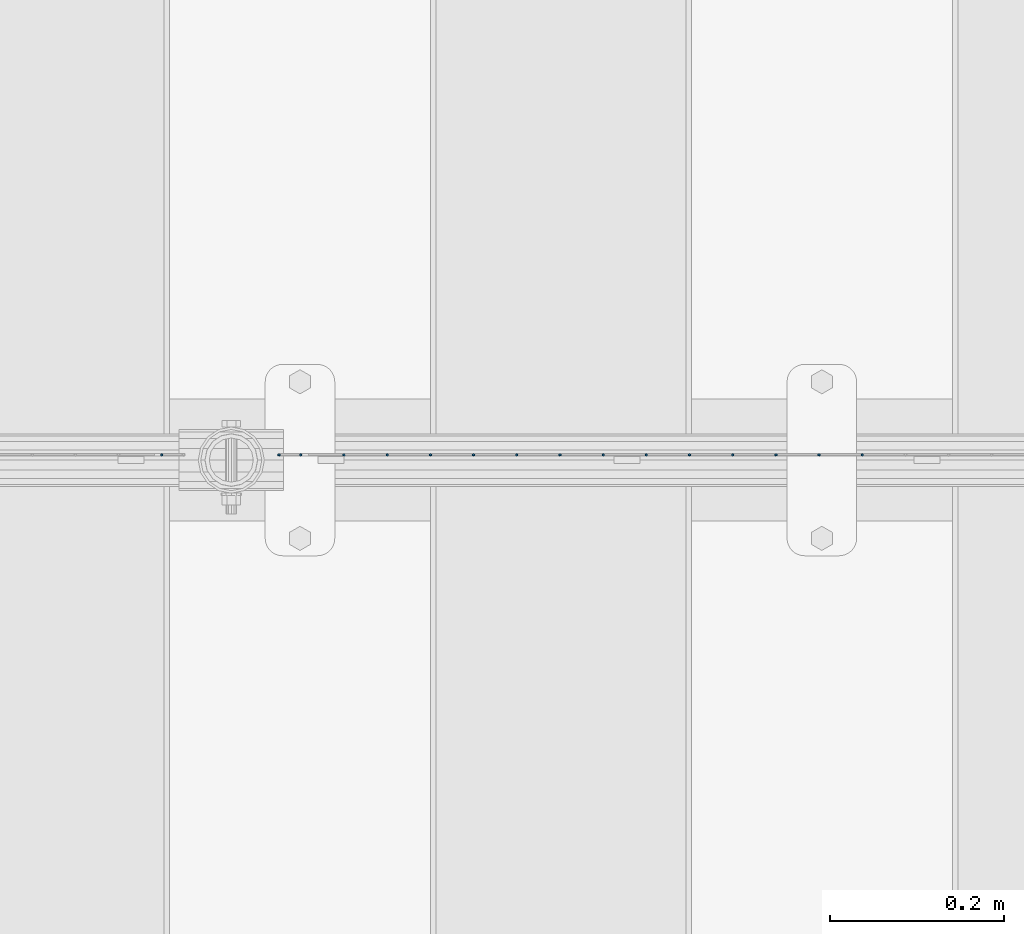
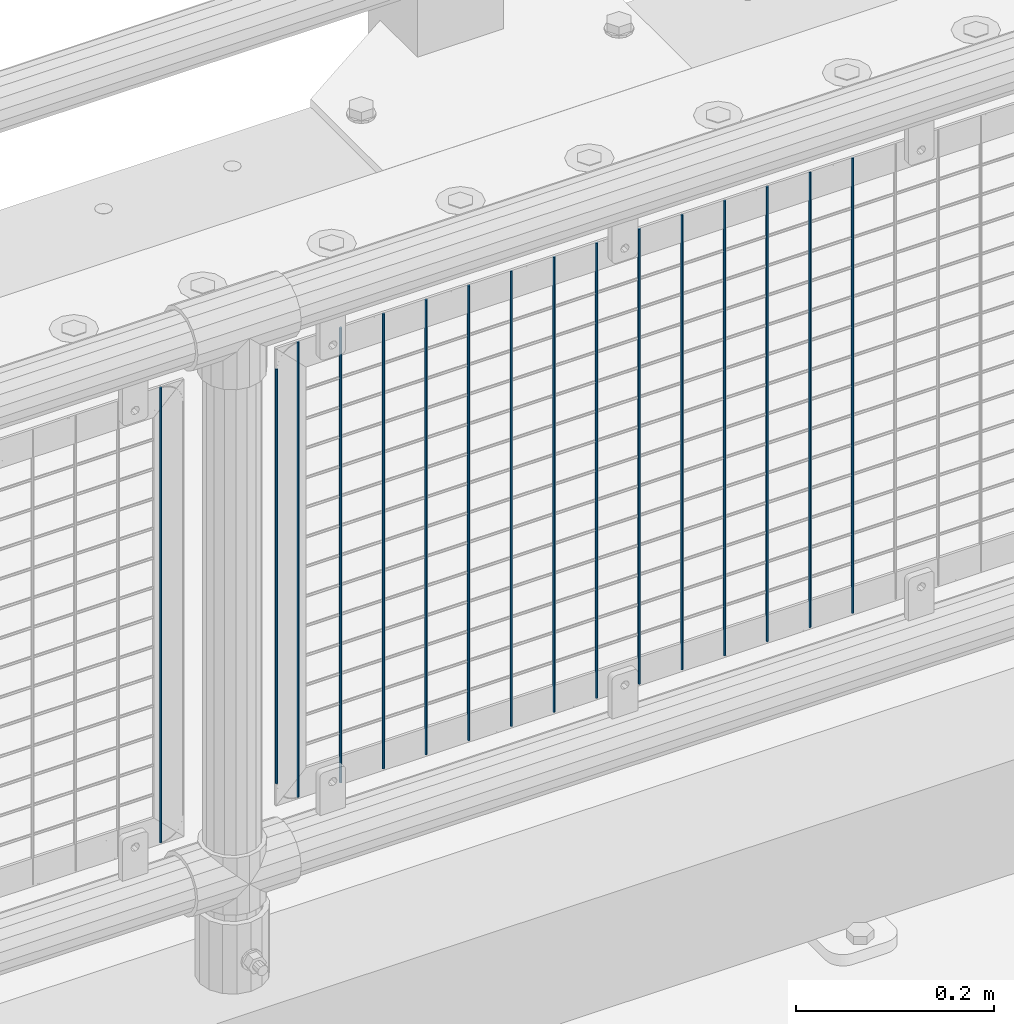
# One storey, part 75 of 208: 16 columns.
"""IFC2X3 building model written with IfcOpenShell, lengths in millimetres."""

from ifc_helpers import new_model, si_unit, frame, origin_with_axes, place, context, subcontext, project, spatial, faceted_brep, material, type_object, element, save


model = new_model("IFC2X3")

# Units and contexts
model_context = context("Model", 3, precision=1e-05, world=origin_with_axes())
body_context = subcontext(model_context, "Body", "Model", "MODEL_VIEW")
ifc_project = project(units=[si_unit("LENGTHUNIT", "METRE", prefix="MILLI"), si_unit("AREAUNIT", "SQUARE_METRE"), si_unit("VOLUMEUNIT", "CUBIC_METRE"), si_unit("MASSUNIT", "GRAM", prefix="KILO"), si_unit("TIMEUNIT", "SECOND"), si_unit("PLANEANGLEUNIT", "RADIAN"), si_unit("SOLIDANGLEUNIT", "STERADIAN"), si_unit("THERMODYNAMICTEMPERATUREUNIT", "DEGREE_CELSIUS"), si_unit("LUMINOUSINTENSITYUNIT", "LUMEN")], contexts=[model_context])

# Site, building, storey
site_placement = place(None, origin_with_axes())
site = spatial("IfcSite", under=ifc_project, at=site_placement, CompositionType="ELEMENT")
building_placement = place(site_placement, origin_with_axes())
building = spatial("IfcBuilding", under=site, at=building_placement, Name="Standard", CompositionType="ELEMENT")
storey_placement = place(building_placement, origin_with_axes())
storey = spatial("IfcBuildingStorey", under=building, at=storey_placement, Name="Undefined", CompositionType="ELEMENT", Elevation=0.0)

# Columns
ifc_material = material(Name="Misc_Undefined")
column_type = type_object("IfcColumnType", Name="D3", PredefinedType="NOTDEFINED")
for number, where, z_axis, x_axis in (
    (1, (-31503.485, 4670.50000000001, 353.020000000004), (-1.0, 0.0, 0.0), (0.0, 0.0, 1.0)),
    (2, (-31553.14, 4670.50000000001, 353.020000000004), (-1.0, 0.0, 0.0), (0.0, 0.0, 1.0)),
    (3, (-31602.795, 4670.50000000001, 353.020000000004), (-1.0, 0.0, 0.0), (0.0, 0.0, 1.0)),
    (4, (-31652.45, 4670.50000000001, 353.020000000004), (-1.0, 0.0, 0.0), (0.0, 0.0, 1.0)),
    (5, (-31702.105, 4670.50000000001, 353.020000000004), (-1.0, 0.0, 0.0), (0.0, 0.0, 1.0)),
    (6, (-31751.76, 4670.50000000001, 353.020000000004), (-1.0, 0.0, 0.0), (0.0, 0.0, 1.0)),
    (7, (-31801.415, 4670.50000000001, 353.020000000004), (-1.0, 0.0, 0.0), (0.0, 0.0, 1.0)),
    (8, (-31851.07, 4670.50000000001, 353.020000000004), (-1.0, 0.0, 0.0), (0.0, 0.0, 1.0)),
    (9, (-31900.725, 4670.50000000001, 353.020000000004), (-1.0, 0.0, 0.0), (0.0, 0.0, 1.0)),
    (10, (-31950.38, 4670.50000000001, 353.020000000004), (-1.0, 0.0, 0.0), (0.0, 0.0, 1.0)),
    (11, (-32000.035, 4670.5, 353.020000000004), (-1.0, 0.0, 0.0), (0.0, 0.0, 1.0)),
    (12, (-32049.6896551724, 4670.5, 353.020000000004), (-1.0, 0.0, 0.0), (0.0, 0.0, 1.0)),
    (13, (-32099.3448275862, 4670.5, 353.020000000004), (-0.999999999962839, 0.0, 8.62099999968473e-06), (8.62099999949798e-06, 0.0, 0.999999999962839)),
):
    element("IfcColumn", number, at=place(storey_placement, frame(where, z_axis=z_axis, x_axis=x_axis)), inside=storey, type_object=column_type, material=ifc_material, ObjectType="D3", context=body_context, shape_type="Brep", body=[
        faceted_brep([(0.0, -1.49999999999909, 3.63797880709171e-12), (-7.27595761418343e-12, -0.749999999999091, -1.29903810567669), (560.0, -0.75, -1.29903810567703), (560.0, -1.5, 0.0), (-3.63797880709171e-12, 0.750000000000909, -1.29903810567669), (560.0, 0.75, -1.29903810567703), (0.0, 1.50000000000182, 3.63797880709171e-12), (560.0, 1.5, 0.0), (-3.63797880709171e-12, 0.750000000000909, 1.29903810567669), (560.0, 0.75, 1.29903810567703), (-7.27595761418343e-12, -0.749999999999091, 1.29903810567669), (560.0, -0.75, 1.29903810567703)], [[[0, 1, 2, 3]], [[1, 4, 5, 2]], [[4, 6, 7, 5]], [[6, 8, 9, 7]], [[8, 10, 11, 9]], [[10, 0, 3, 11]], [[5, 7, 9, 11, 3, 2]], [[10, 8, 6, 4, 1, 0]]]),
    ])
column_placement = place(storey_placement, frame((-32174.0, 4670.5, 378.020000000004), z_axis=(-1.0, 0.0, 0.0), x_axis=(0.0, 0.0, 1.0)))
element("IfcColumn", 14, at=column_placement, inside=storey, type_object=column_type, material=ifc_material, ObjectType="D3", context=body_context, shape_type="Brep", body=[
    faceted_brep([(0.0, -1.49999999999909, 3.63797880709171e-12), (-7.27595761418343e-12, -0.749999999999091, -1.29903810567669), (510.0, -0.75, -1.29903810567703), (510.0, -1.5, 0.0), (-3.63797880709171e-12, 0.750000000000909, -1.29903810567669), (510.0, 0.75, -1.29903810567703), (0.0, 1.50000000000182, 3.63797880709171e-12), (510.0, 1.5, 0.0), (-3.63797880709171e-12, 0.750000000000909, 1.29903810567669), (510.0, 0.75, 1.29903810567703), (-7.27595761418343e-12, -0.749999999999091, 1.29903810567669), (510.0, -0.75, 1.29903810567703)], [[[0, 1, 2, 3]], [[1, 4, 5, 2]], [[4, 6, 7, 5]], [[6, 8, 9, 7]], [[8, 10, 11, 9]], [[10, 0, 3, 11]], [[5, 7, 9, 11, 3, 2]], [[10, 8, 6, 4, 1, 0]]]),
])
for number, where, z_axis, x_axis in (
    (15, (-32149.0, 4670.5, 353.020000000004), (-1.0, 0.0, 0.0), (0.0, 0.0, 1.0)),
    (16, (-32309.005, 4670.50000000001, 353.020000000003), (-1.0, 0.0, 0.0), (0.0, 0.0, 1.0)),
):
    element("IfcColumn", number, at=place(storey_placement, frame(where, z_axis=z_axis, x_axis=x_axis)), inside=storey, type_object=column_type, material=ifc_material, ObjectType="D3", context=body_context, shape_type="Brep", body=[
        faceted_brep([(0.0, -1.49999999999909, 3.63797880709171e-12), (-7.27595761418343e-12, -0.749999999999091, -1.29903810567669), (560.0, -0.75, -1.29903810567703), (560.0, -1.5, 0.0), (-3.63797880709171e-12, 0.750000000000909, -1.29903810567669), (560.0, 0.75, -1.29903810567703), (0.0, 1.50000000000182, 3.63797880709171e-12), (560.0, 1.5, 0.0), (-3.63797880709171e-12, 0.750000000000909, 1.29903810567669), (560.0, 0.75, 1.29903810567703), (-7.27595761418343e-12, -0.749999999999091, 1.29903810567669), (560.0, -0.75, 1.29903810567703)], [[[0, 1, 2, 3]], [[1, 4, 5, 2]], [[4, 6, 7, 5]], [[6, 8, 9, 7]], [[8, 10, 11, 9]], [[10, 0, 3, 11]], [[5, 7, 9, 11, 3, 2]], [[10, 8, 6, 4, 1, 0]]]),
    ])

save(model, "model.ifc")
